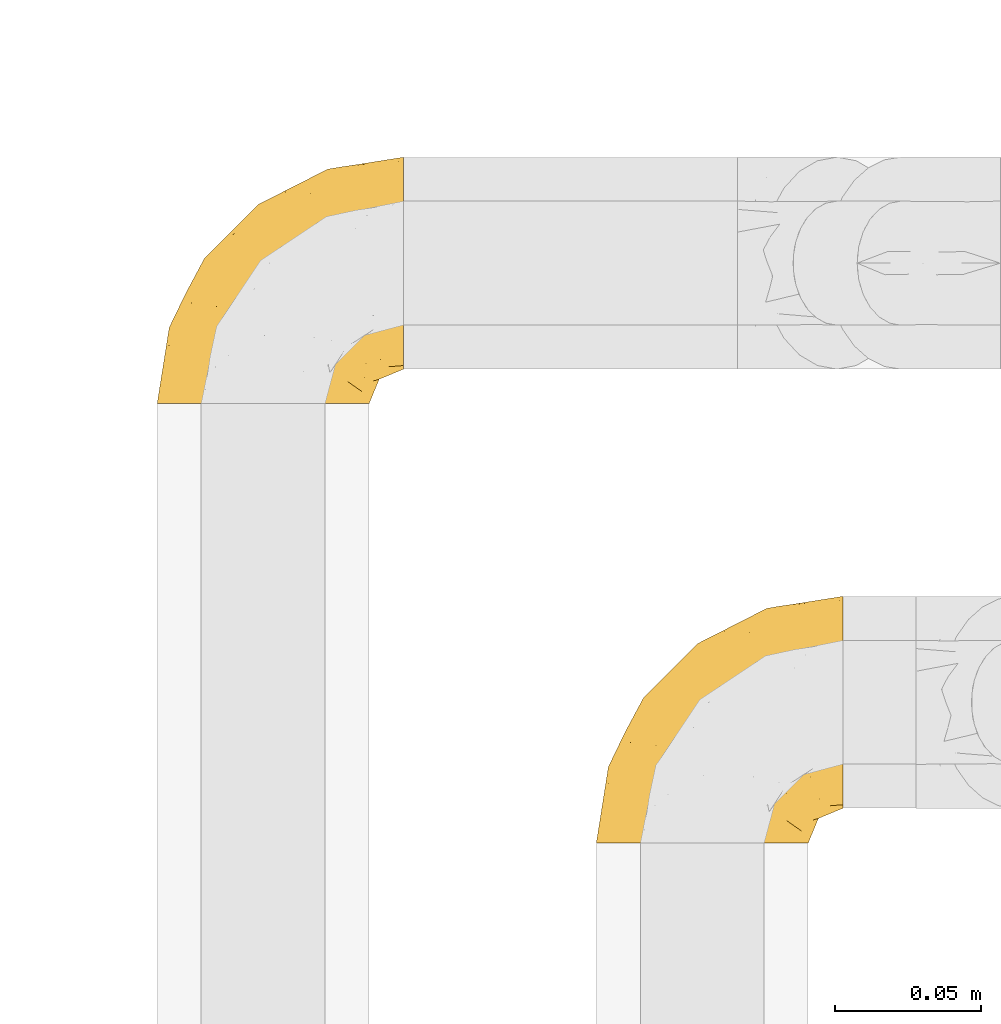
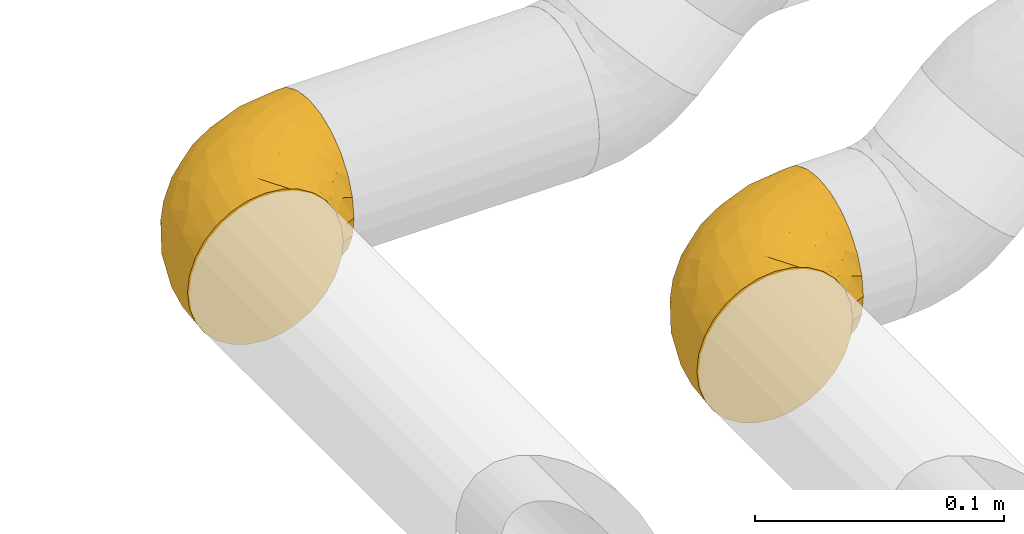
# One storey, part 18 of 39: 2 coverings.
"""IFC2X3 building model written with IfcOpenShell, lengths in millimetres."""

from ifc_helpers import new_model, entity, si_unit, converted_unit, derived_unit, direction, frame, origin, place, context, subcontext, project, spatial, faceted_brep, element, save


model = new_model("IFC2X3")

# Units and contexts
model_context = context("Model", 3, precision=0.01, world=origin(), true_north=direction((6.12303176911189e-17, 1.0)))
body_context = subcontext(model_context, "Body", "Model", "MODEL_VIEW")
ifc_project = project(units=[si_unit("LENGTHUNIT", "METRE", prefix="MILLI"), si_unit("AREAUNIT", "SQUARE_METRE"), si_unit("VOLUMEUNIT", "CUBIC_METRE"), converted_unit("PLANEANGLEUNIT", "DEGREE", entity("IfcRatioMeasure", 0.0174532925199433), si_unit("PLANEANGLEUNIT", "RADIAN"), dimensions=[0, 0, 0, 0, 0, 0, 0]), si_unit("MASSUNIT", "GRAM", prefix="KILO"), derived_unit("MASSDENSITYUNIT", [(si_unit("MASSUNIT", "GRAM", prefix="KILO"), 1), (si_unit("LENGTHUNIT", "METRE"), -3)]), derived_unit("MOMENTOFINERTIAUNIT", [(si_unit("LENGTHUNIT", "METRE"), 4)]), si_unit("TIMEUNIT", "SECOND"), si_unit("FREQUENCYUNIT", "HERTZ"), si_unit("THERMODYNAMICTEMPERATUREUNIT", "DEGREE_CELSIUS"), derived_unit("THERMALTRANSMITTANCEUNIT", [(si_unit("MASSUNIT", "GRAM", prefix="KILO"), 1), (si_unit("THERMODYNAMICTEMPERATUREUNIT", "KELVIN"), -1), (si_unit("TIMEUNIT", "SECOND"), -3)]), derived_unit("VOLUMETRICFLOWRATEUNIT", [(si_unit("LENGTHUNIT", "METRE"), 3), (si_unit("TIMEUNIT", "SECOND"), -1)]), derived_unit("MASSFLOWRATEUNIT", [(si_unit("MASSUNIT", "GRAM", prefix="KILO"), 1), (si_unit("TIMEUNIT", "SECOND"), -1)]), derived_unit("ROTATIONALFREQUENCYUNIT", [(si_unit("TIMEUNIT", "SECOND"), -1)]), si_unit("ELECTRICCURRENTUNIT", "AMPERE"), si_unit("ELECTRICVOLTAGEUNIT", "VOLT"), si_unit("POWERUNIT", "WATT"), si_unit("FORCEUNIT", "NEWTON", prefix="KILO"), si_unit("ILLUMINANCEUNIT", "LUX"), si_unit("LUMINOUSFLUXUNIT", "LUMEN"), si_unit("LUMINOUSINTENSITYUNIT", "CANDELA"), derived_unit("USERDEFINED", [(si_unit("MASSUNIT", "GRAM", prefix="KILO"), -1), (si_unit("LENGTHUNIT", "METRE"), -2), (si_unit("TIMEUNIT", "SECOND"), 3), (si_unit("LUMINOUSFLUXUNIT", "LUMEN"), 1)]), derived_unit("LINEARVELOCITYUNIT", [(si_unit("LENGTHUNIT", "METRE"), 1), (si_unit("TIMEUNIT", "SECOND"), -1)]), si_unit("PRESSUREUNIT", "PASCAL"), derived_unit("USERDEFINED", [(si_unit("LENGTHUNIT", "METRE"), -2), (si_unit("MASSUNIT", "GRAM", prefix="KILO"), 1), (si_unit("TIMEUNIT", "SECOND"), -2)]), derived_unit("LINEARFORCEUNIT", [(si_unit("MASSUNIT", "GRAM", prefix="KILO"), 1), (si_unit("LENGTHUNIT", "METRE"), 1), (si_unit("TIMEUNIT", "SECOND"), -2), (si_unit("LENGTHUNIT", "METRE"), -1)]), derived_unit("PLANARFORCEUNIT", [(si_unit("MASSUNIT", "GRAM", prefix="KILO"), 1), (si_unit("LENGTHUNIT", "METRE"), 1), (si_unit("TIMEUNIT", "SECOND"), -2), (si_unit("LENGTHUNIT", "METRE"), -2)])], contexts=[model_context])

# Site, building, storey
site_placement = place(None, origin())
site = spatial("IfcSite", under=ifc_project, at=site_placement, CompositionType="ELEMENT")
building_placement = place(site_placement, origin())
building = spatial("IfcBuilding", under=site, at=building_placement, CompositionType="ELEMENT")
storey_placement = place(building_placement, frame((0.0, 0.0, 24000.0)))
storey = spatial("IfcBuildingStorey", under=building, at=storey_placement, Name="07", CompositionType="ELEMENT", Elevation=24000.0)

# Coverings
covering_1_placement = place(storey_placement, frame((68632.28, 2675.76, 2992.16)))
element("IfcCovering", 1, at=covering_1_placement, inside=storey, Name=":ADSK_", ObjectType=":ADSK_", PredefinedType="INSULATION", context=body_context, shape_type="Brep", body=[
    faceted_brep([(37.79, 1.6, 74.0), (29.74, 1.6, 73.09), (22.08, 1.6, 70.41), (15.22, 1.6, 66.09), (9.49, 1.6, 60.36), (5.18, 1.6, 53.5), (2.5, 1.6, 45.85), (1.6, 1.6, 37.79), (2.5, 1.6, 29.74), (5.18, 1.6, 22.08), (9.5, 1.6, 15.22), (15.23, 1.6, 9.49), (22.09, 1.6, 5.18), (29.75, 1.6, 2.5), (37.8, 1.6, 1.6), (43.06, 1.6, 2.19), (45.86, 1.6, 2.5), (49.68, 1.6, 3.84), (53.51, 1.6, 5.18), (60.37, 1.6, 9.5), (66.1, 1.6, 15.23), (70.41, 1.6, 22.09), (73.09, 1.6, 29.75), (74.0, 1.6, 37.8), (73.09, 1.6, 45.86), (70.41, 1.6, 53.51), (66.09, 1.6, 60.37), (60.36, 1.6, 66.1), (53.5, 1.6, 70.41), (49.67, 1.6, 71.75), (45.85, 1.6, 73.09), (43.06, 1.6, 73.4), (85.8, 14.63, 28.43), (85.8, 18.25, 19.7), (85.8, 24.0, 12.2), (85.8, 27.75, 9.32), (85.8, 31.5, 6.45), (85.8, 35.86, 4.64), (85.8, 40.23, 2.83), (85.8, 44.31, 2.29), (85.8, 46.95, 1.94), (85.8, 49.6, 1.6), (85.8, 58.96, 2.83), (85.8, 67.7, 6.45), (85.8, 75.19, 12.2), (85.8, 80.95, 19.7), (85.8, 84.56, 28.43), (85.8, 85.8, 37.8), (85.8, 84.56, 47.17), (85.79, 80.95, 55.9), (85.79, 75.19, 63.39), (85.79, 67.7, 69.15), (85.79, 58.96, 72.76), (85.79, 49.6, 74.0), (85.79, 44.31, 73.3), (85.79, 40.23, 72.76), (85.79, 35.86, 70.95), (85.79, 31.5, 69.15), (85.79, 27.75, 66.27), (85.79, 24.0, 63.39), (85.79, 18.25, 55.9), (85.8, 14.63, 47.17), (85.8, 13.4, 37.8), (27.78, 59.61, 50.11), (26.99, 60.4, 37.8), (19.14, 51.32, 46.44), (59.78, 81.67, 37.8), (64.45, 82.49, 44.03), (67.99, 82.98, 37.8), (45.3, 73.87, 47.59), (53.86, 73.39, 57.17), (66.01, 81.11, 50.38), (70.92, 77.75, 58.65), (33.16, 16.46, 73.37), (49.16, 51.34, 71.27), (68.28, 63.37, 70.16), (50.64, 61.46, 66.97), (70.36, 54.83, 73.22), (67.43, 45.94, 74.0), (74.88, 47.42, 74.0), (77.61, 47.97, 74.0), (80.34, 48.51, 74.0), (65.68, 70.77, 64.86), (24.84, 15.75, 70.93), (11.5, 39.56, 45.19), (5.67, 21.48, 48.57), (13.35, 36.01, 54.32), (39.73, 34.58, 72.94), (41.45, 19.96, 74.0), (44.05, 23.86, 74.0), (46.65, 27.75, 74.0), (49.25, 31.64, 74.0), (51.85, 35.54, 74.0), (35.98, 46.13, 68.72), (57.18, 48.41, 73.34), (18.48, 16.74, 67.28), (13.36, 21.75, 61.7), (7.85, 16.31, 55.93), (4.42, 19.4, 37.79), (20.15, 48.77, 53.02), (31.91, 58.66, 57.31), (38.88, 7.05, 74.0), (39.97, 12.51, 74.0), (21.9, 34.87, 64.86), (22.4, 45.71, 59.15), (28.44, 30.95, 70.05), (41.69, 67.5, 55.98), (48.04, 75.69, 37.8), (33.67, 53.35, 63.54), (44.49, 64.73, 61.4), (5.72, 27.61, 37.79), (17.68, 51.09, 37.79), (11.7, 39.35, 37.79), (55.75, 38.14, 74.0), (59.64, 40.74, 74.0), (63.53, 43.34, 74.0), (36.3, 69.71, 37.8), (69.92, 30.92, 70.9), (69.03, 26.47, 69.2), (74.68, 24.1, 65.83), (79.55, 42.08, 73.31), (79.54, 27.56, 67.07), (81.25, 22.68, 62.53), (76.19, 12.9, 52.3), (72.4, 10.56, 54.94), (75.54, 9.38, 46.54), (63.7, 30.49, 72.08), (66.91, 37.21, 73.17), (72.9, 15.4, 59.32), (77.88, 16.56, 56.36), (80.8, 14.21, 48.99), (80.78, 19.1, 58.36), (60.93, 6.65, 66.05), (66.56, 9.22, 61.56), (58.7, 13.56, 68.98), (46.01, 10.43, 73.26), (80.23, 32.68, 70.06), (70.42, 40.02, 73.39), (74.75, 33.01, 70.87), (68.99, 13.09, 61.17), (51.42, 11.85, 71.9), (71.01, 20.93, 65.19), (76.08, 6.64, 37.8), (73.71, 5.68, 46.04), (71.61, 5.7, 52.15), (63.33, 14.76, 66.57), (77.45, 9.94, 37.8), (52.09, 25.2, 73.34), (50.98, 19.66, 72.91), (80.75, 11.31, 37.8), (76.87, 39.13, 72.75), (57.73, 30.86, 73.22), (63.89, 24.56, 70.14), (57.77, 25.09, 72.14), (66.53, 18.54, 66.28), (80.78, 19.1, 17.24), (80.8, 14.22, 26.6), (81.26, 22.68, 13.06), (38.88, 7.05, 1.6), (39.97, 12.51, 1.6), (73.72, 5.68, 29.56), (72.41, 10.57, 20.66), (71.61, 5.7, 23.45), (66.57, 9.22, 14.05), (74.88, 47.42, 1.6), (80.34, 48.51, 1.6), (83.07, 49.05, 1.6), (77.88, 16.56, 19.23), (76.2, 12.9, 23.3), (72.91, 15.39, 16.29), (77.21, 27.52, 8.09), (74.75, 33.0, 4.72), (80.23, 32.67, 5.54), (51.43, 11.86, 3.69), (76.87, 39.13, 2.84), (66.92, 37.21, 2.42), (69.93, 30.92, 4.69), (63.71, 30.49, 3.52), (70.42, 40.02, 2.21), (75.54, 9.38, 29.05), (79.55, 42.08, 2.29), (60.94, 6.65, 9.55), (69.0, 13.09, 14.43), (46.02, 10.43, 2.33), (66.54, 18.54, 9.32), (57.77, 25.08, 3.45), (63.89, 24.56, 5.45), (71.03, 20.93, 10.41), (51.53, 19.57, 2.81), (58.72, 13.56, 6.62), (41.45, 19.96, 1.6), (74.69, 24.1, 9.76), (63.35, 14.76, 9.03), (57.73, 30.85, 2.37), (49.25, 31.64, 1.6), (56.44, 20.0, 4.15), (51.59, 25.27, 2.17), (44.05, 23.86, 1.6), (59.64, 40.74, 1.6), (55.75, 38.14, 1.6), (67.43, 45.94, 1.6), (63.53, 43.34, 1.6), (69.03, 26.46, 6.39), (46.65, 27.75, 1.6), (51.85, 35.54, 1.6), (49.16, 51.33, 4.32), (70.36, 54.83, 2.37), (57.19, 48.41, 2.25), (22.41, 45.7, 16.43), (31.92, 58.67, 18.27), (33.68, 53.34, 12.04), (50.63, 61.46, 8.62), (35.99, 46.13, 6.87), (21.91, 34.86, 10.72), (39.73, 34.58, 2.64), (27.78, 59.61, 25.48), (41.7, 67.49, 19.59), (68.28, 63.37, 5.43), (64.45, 82.49, 31.57), (66.0, 81.11, 25.21), (28.45, 30.94, 5.53), (70.92, 77.75, 16.94), (65.68, 70.77, 10.73), (53.85, 73.39, 18.42), (13.35, 36.01, 21.26), (5.67, 21.48, 27.01), (11.5, 39.57, 30.39), (33.16, 16.45, 2.22), (13.37, 21.75, 13.88), (18.49, 16.74, 8.3), (45.3, 73.87, 28.0), (19.15, 51.31, 29.14), (20.15, 48.77, 22.56), (7.85, 16.32, 19.64), (44.48, 64.71, 14.18), (24.85, 15.75, 4.66)], [[[0, 1, 2, 3, 4, 5, 6, 7, 8, 9, 10, 11, 12, 13, 14, 15, 16, 17, 18, 19, 20, 21, 22, 23, 24, 25, 26, 27, 28, 29, 30, 31]], [[32, 33, 34, 35, 36, 37, 38, 39, 40, 41, 42, 43, 44, 45, 46, 47, 48, 49, 50, 51, 52, 53, 54, 55, 56, 57, 58, 59, 60, 61, 62]], [[63, 64, 65]], [[66, 67, 68]], [[69, 70, 71]], [[71, 70, 72]], [[73, 1, 0]], [[74, 75, 76]], [[49, 48, 71]], [[77, 78, 79, 80, 81, 53]], [[50, 82, 51]], [[72, 50, 49]], [[2, 1, 83]], [[84, 85, 86]], [[87, 88, 89, 90, 91, 92]], [[53, 52, 77]], [[93, 74, 76]], [[5, 85, 6]], [[94, 78, 77]], [[95, 3, 2]], [[95, 96, 3]], [[75, 51, 82]], [[85, 5, 97]], [[50, 72, 82]], [[97, 5, 4]], [[85, 98, 6]], [[94, 87, 92]], [[74, 77, 75]], [[99, 100, 63]], [[96, 4, 3]], [[73, 0, 101, 102, 88]], [[96, 103, 104]], [[48, 68, 67]], [[84, 99, 65]], [[105, 83, 73]], [[105, 95, 83]], [[100, 106, 63]], [[86, 96, 104]], [[97, 86, 85]], [[67, 107, 69]], [[100, 108, 109]], [[84, 110, 85]], [[93, 87, 74]], [[96, 95, 103]], [[69, 71, 67]], [[70, 69, 106]], [[4, 96, 97]], [[86, 97, 96]], [[83, 95, 2]], [[103, 95, 105]], [[93, 103, 105]], [[103, 108, 104]], [[75, 77, 52]], [[94, 77, 74]], [[51, 75, 52]], [[75, 82, 76]], [[109, 82, 70]], [[93, 76, 108]], [[88, 87, 73]], [[105, 73, 87]], [[84, 86, 99]], [[84, 111, 112, 110]], [[98, 85, 110]], [[98, 7, 6]], [[73, 83, 1]], [[71, 72, 49]], [[82, 72, 70]], [[87, 94, 74]], [[94, 92, 113, 114, 115, 78]], [[48, 47, 68]], [[48, 67, 71]], [[100, 104, 108]], [[99, 86, 104]], [[109, 108, 76]], [[100, 109, 106]], [[82, 109, 76]], [[106, 109, 70]], [[100, 99, 104]], [[99, 63, 65]], [[69, 116, 63]], [[111, 84, 65]], [[64, 63, 116]], [[64, 111, 65]], [[63, 106, 69]], [[103, 93, 108]], [[87, 93, 105]], [[107, 67, 66]], [[107, 116, 69]], [[117, 118, 119]], [[80, 120, 55]], [[121, 119, 122]], [[120, 56, 55]], [[123, 124, 125]], [[114, 126, 127]], [[101, 0, 31, 30, 102]], [[123, 128, 124]], [[129, 123, 130]], [[60, 122, 131]], [[132, 133, 134]], [[29, 28, 135]], [[131, 61, 60]], [[122, 60, 59]], [[136, 137, 138]], [[124, 128, 139]], [[132, 27, 26]], [[131, 130, 61]], [[140, 135, 28]], [[102, 29, 135]], [[119, 118, 141]], [[58, 136, 121]], [[140, 28, 27]], [[54, 53, 81, 80, 55]], [[23, 142, 143]], [[24, 144, 25]], [[25, 144, 133]], [[26, 25, 133]], [[134, 133, 145]], [[125, 142, 146]], [[124, 143, 125]], [[147, 90, 148]], [[124, 144, 143]], [[149, 125, 146]], [[150, 57, 56]], [[137, 78, 115]], [[130, 62, 61]], [[132, 140, 27]], [[151, 152, 126]], [[140, 134, 148]], [[148, 89, 140]], [[120, 78, 150]], [[115, 127, 137]], [[137, 136, 150]], [[78, 120, 80, 79]], [[150, 56, 120]], [[91, 151, 92]], [[127, 117, 138]], [[144, 24, 143]], [[133, 144, 124]], [[153, 91, 147]], [[145, 153, 134]], [[23, 143, 24]], [[142, 125, 143]], [[130, 125, 149]], [[128, 123, 129]], [[141, 129, 119]], [[124, 139, 133]], [[125, 130, 123]], [[62, 130, 149]], [[128, 154, 139]], [[145, 139, 154]], [[92, 151, 113]], [[127, 115, 114]], [[117, 127, 126]], [[118, 117, 126]], [[121, 117, 119]], [[138, 137, 127]], [[78, 137, 150]], [[152, 118, 126]], [[118, 152, 141]], [[154, 128, 141]], [[129, 141, 128]], [[102, 30, 29]], [[140, 88, 135]], [[88, 102, 135]], [[133, 132, 26]], [[140, 132, 134]], [[121, 122, 59]], [[131, 119, 129]], [[121, 59, 58]], [[121, 138, 117]], [[136, 58, 57]], [[150, 136, 57]], [[121, 136, 138]], [[119, 131, 122]], [[131, 129, 130]], [[139, 145, 133]], [[153, 145, 154]], [[89, 148, 90]], [[89, 88, 140]], [[147, 134, 153]], [[134, 147, 148]], [[126, 114, 113]], [[153, 151, 91]], [[91, 90, 147]], [[153, 154, 152]], [[152, 154, 141]], [[152, 151, 153]], [[113, 151, 126]], [[155, 32, 156]], [[33, 157, 34]], [[62, 149, 156]], [[15, 14, 158, 159, 16]], [[160, 23, 22]], [[161, 162, 163]], [[40, 39, 38, 164, 165, 166, 41]], [[167, 168, 169]], [[157, 170, 34]], [[171, 172, 170]], [[18, 173, 19]], [[174, 37, 36]], [[175, 176, 177]], [[178, 171, 175]], [[146, 179, 149]], [[168, 179, 161]], [[161, 160, 162]], [[162, 160, 22]], [[38, 37, 180]], [[20, 19, 181]], [[21, 20, 163]], [[161, 182, 169]], [[18, 183, 173]], [[184, 185, 186]], [[169, 187, 167]], [[188, 189, 173]], [[159, 190, 183]], [[17, 159, 183]], [[156, 179, 168]], [[191, 157, 155]], [[192, 163, 189]], [[21, 162, 22]], [[146, 142, 179]], [[181, 163, 20]], [[193, 185, 194]], [[178, 172, 171]], [[167, 156, 168]], [[185, 195, 196]], [[181, 173, 189]], [[173, 197, 188]], [[198, 177, 199]], [[200, 164, 180]], [[180, 164, 38]], [[201, 178, 175]], [[37, 174, 180]], [[200, 180, 174]], [[175, 198, 201]], [[177, 176, 202]], [[163, 162, 21]], [[160, 161, 179]], [[192, 185, 184]], [[195, 189, 188]], [[179, 142, 160]], [[23, 160, 142]], [[169, 168, 161]], [[155, 156, 167]], [[182, 161, 163]], [[184, 186, 187]], [[62, 156, 32]], [[179, 156, 149]], [[192, 182, 163]], [[184, 169, 182]], [[176, 175, 171]], [[174, 178, 200]], [[198, 175, 177]], [[170, 176, 171]], [[202, 176, 191]], [[200, 178, 201]], [[178, 174, 172]], [[187, 202, 191]], [[202, 187, 186]], [[167, 187, 191]], [[169, 184, 187]], [[173, 183, 190]], [[17, 16, 159]], [[173, 181, 19]], [[163, 181, 189]], [[155, 157, 33]], [[170, 157, 191]], [[176, 170, 191]], [[35, 170, 172]], [[35, 172, 36]], [[34, 170, 35]], [[174, 36, 172]], [[32, 155, 33]], [[191, 155, 167]], [[192, 189, 195]], [[182, 192, 184]], [[193, 199, 177]], [[183, 18, 17]], [[197, 173, 190]], [[197, 203, 188]], [[193, 186, 185]], [[202, 186, 177]], [[188, 196, 195]], [[204, 193, 194]], [[188, 203, 196]], [[192, 195, 185]], [[203, 194, 196]], [[185, 196, 194]], [[199, 193, 204]], [[186, 193, 177]], [[205, 206, 207]], [[208, 209, 210]], [[210, 211, 212]], [[210, 213, 208]], [[214, 204, 194, 203, 197, 190]], [[206, 41, 166, 165, 164, 200]], [[215, 216, 209]], [[206, 217, 42]], [[218, 46, 219]], [[207, 214, 205]], [[212, 214, 220]], [[221, 219, 45]], [[45, 219, 46]], [[221, 222, 223]], [[224, 225, 226]], [[222, 44, 43]], [[222, 217, 211]], [[220, 214, 227]], [[227, 190, 159, 158, 14]], [[217, 43, 42]], [[14, 13, 227]], [[225, 9, 8]], [[10, 228, 11]], [[11, 229, 12]], [[208, 213, 228]], [[228, 229, 11]], [[230, 219, 223]], [[231, 232, 226]], [[231, 64, 215]], [[225, 233, 9]], [[229, 213, 220]], [[233, 10, 9]], [[110, 225, 98]], [[41, 206, 42]], [[222, 211, 234]], [[224, 228, 233]], [[225, 8, 98]], [[221, 45, 44]], [[226, 110, 112, 111]], [[12, 229, 235]], [[46, 218, 68]], [[230, 107, 218]], [[223, 234, 216]], [[107, 66, 218]], [[224, 233, 225]], [[228, 10, 233]], [[213, 229, 228]], [[235, 229, 220]], [[208, 228, 224]], [[212, 213, 210]], [[207, 206, 200]], [[205, 211, 217]], [[205, 217, 206]], [[43, 217, 222]], [[212, 211, 205]], [[210, 209, 234]], [[227, 13, 235]], [[214, 190, 227]], [[110, 226, 225]], [[232, 231, 215]], [[8, 7, 98]], [[227, 235, 220]], [[13, 12, 235]], [[222, 221, 44]], [[219, 221, 223]], [[207, 200, 201, 198, 199, 204]], [[214, 207, 204]], [[68, 218, 66]], [[68, 47, 46]], [[230, 218, 219]], [[224, 232, 208]], [[208, 232, 209]], [[216, 215, 230]], [[210, 234, 211]], [[216, 234, 209]], [[222, 234, 223]], [[226, 232, 224]], [[209, 232, 215]], [[226, 111, 231]], [[64, 116, 215]], [[231, 111, 64]], [[116, 230, 215]], [[230, 223, 216]], [[214, 212, 205]], [[213, 212, 220]], [[230, 116, 107]]]),
])
covering_2_placement = place(storey_placement, frame((68482.28, 2825.76, 2992.19)))
element("IfcCovering", 2, at=covering_2_placement, inside=storey, Name=":ADSK_", ObjectType=":ADSK_", PredefinedType="INSULATION", context=body_context, shape_type="Brep", body=[
    faceted_brep([(15.23, 1.6, 66.11), (9.49, 1.6, 60.37), (5.18, 1.6, 53.51), (2.5, 1.6, 45.86), (1.6, 1.6, 37.81), (2.5, 1.6, 29.75), (5.18, 1.6, 22.1), (9.49, 1.6, 15.23), (15.22, 1.6, 9.5), (22.09, 1.6, 5.19), (29.74, 1.6, 2.51), (37.79, 1.6, 1.6), (43.05, 1.6, 2.19), (45.85, 1.6, 2.51), (49.67, 1.6, 3.85), (53.5, 1.6, 5.19), (60.36, 1.6, 9.5), (66.1, 1.6, 15.23), (70.41, 1.6, 22.09), (73.09, 1.6, 29.74), (74.0, 1.6, 37.79), (73.09, 1.6, 45.85), (70.41, 1.6, 53.51), (66.1, 1.6, 60.37), (60.37, 1.6, 66.1), (53.5, 1.6, 70.42), (49.68, 1.6, 71.76), (45.85, 1.6, 73.09), (43.06, 1.6, 73.41), (37.8, 1.6, 74.0), (29.74, 1.6, 73.1), (22.09, 1.6, 70.42), (85.79, 14.63, 28.42), (85.79, 18.25, 19.69), (85.79, 24.0, 12.2), (85.79, 27.75, 9.32), (85.79, 31.5, 6.44), (85.79, 35.87, 4.64), (85.79, 40.23, 2.83), (85.79, 44.32, 2.29), (85.79, 46.96, 1.94), (85.79, 49.6, 1.6), (85.79, 58.97, 2.83), (85.79, 67.7, 6.45), (85.79, 75.2, 12.2), (85.79, 80.95, 19.7), (85.79, 84.57, 28.43), (85.8, 85.8, 37.8), (85.8, 84.56, 47.17), (85.8, 80.95, 55.9), (85.8, 75.19, 63.39), (85.8, 67.7, 69.15), (85.8, 58.96, 72.76), (85.8, 49.6, 74.0), (85.8, 44.31, 73.3), (85.8, 40.23, 72.76), (85.8, 35.86, 70.95), (85.8, 31.5, 69.14), (85.8, 27.75, 66.27), (85.8, 24.0, 63.39), (85.8, 18.25, 55.89), (85.8, 14.63, 47.16), (85.8, 13.4, 37.79), (27.79, 59.61, 50.13), (26.99, 60.4, 37.81), (19.15, 51.32, 46.45), (59.78, 81.68, 37.8), (64.45, 82.49, 44.03), (67.99, 82.98, 37.8), (45.31, 73.88, 47.6), (53.87, 73.4, 57.18), (66.01, 81.12, 50.38), (70.93, 77.75, 58.65), (33.17, 16.46, 73.38), (49.17, 51.34, 71.28), (68.29, 63.37, 70.17), (50.64, 61.46, 66.98), (70.37, 54.83, 73.23), (67.44, 45.94, 74.0), (74.89, 47.42, 74.0), (77.62, 47.97, 74.0), (80.35, 48.51, 74.0), (65.69, 70.77, 64.87), (24.84, 15.75, 70.94), (11.5, 39.56, 45.21), (5.67, 21.48, 48.58), (13.35, 36.02, 54.33), (39.74, 34.58, 72.95), (41.46, 19.96, 74.0), (44.06, 23.86, 74.0), (46.66, 27.75, 74.0), (49.26, 31.64, 74.0), (51.86, 35.54, 74.0), (35.99, 46.13, 68.73), (57.19, 48.41, 73.34), (18.48, 16.74, 67.29), (13.37, 21.75, 61.71), (7.85, 16.32, 55.95), (4.42, 19.4, 37.81), (20.15, 48.78, 53.04), (31.91, 58.66, 57.32), (38.89, 7.05, 74.0), (39.97, 12.51, 74.0), (21.91, 34.87, 64.88), (22.41, 45.71, 59.17), (28.45, 30.95, 70.06), (41.69, 67.5, 55.99), (48.04, 75.7, 37.81), (33.68, 53.35, 63.55), (44.5, 64.73, 61.41), (5.72, 27.62, 37.81), (17.68, 51.09, 37.81), (11.7, 39.35, 37.81), (55.76, 38.14, 74.0), (59.65, 40.74, 74.0), (63.54, 43.34, 74.0), (36.3, 69.72, 37.81), (69.93, 30.92, 70.9), (69.03, 26.47, 69.2), (74.68, 24.1, 65.83), (79.55, 42.08, 73.31), (79.55, 27.56, 67.07), (81.26, 22.68, 62.53), (76.19, 12.9, 52.3), (72.41, 10.57, 54.94), (75.55, 9.38, 46.54), (63.71, 30.49, 72.08), (66.92, 37.21, 73.17), (72.9, 15.4, 59.32), (77.89, 16.56, 56.36), (80.8, 14.22, 48.98), (80.79, 19.1, 58.35), (60.94, 6.65, 66.05), (66.57, 9.22, 61.56), (58.71, 13.56, 68.98), (46.02, 10.43, 73.27), (80.24, 32.68, 70.05), (70.43, 40.02, 73.39), (74.76, 33.01, 70.88), (68.99, 13.09, 61.17), (51.43, 11.85, 71.91), (71.02, 20.93, 65.19), (76.08, 6.64, 37.79), (73.72, 5.68, 46.04), (71.61, 5.7, 52.15), (63.34, 14.76, 66.57), (77.45, 9.94, 37.79), (52.1, 25.2, 73.35), (50.99, 19.66, 72.92), (80.75, 11.31, 37.79), (76.88, 39.14, 72.75), (63.9, 24.56, 70.14), (57.78, 25.09, 72.15), (66.53, 18.54, 66.28), (57.74, 30.86, 73.22), (80.78, 19.1, 17.23), (80.8, 14.22, 26.6), (81.25, 22.68, 13.06), (38.87, 7.06, 1.6), (39.96, 12.52, 1.6), (73.72, 5.68, 29.56), (72.4, 10.57, 20.66), (71.61, 5.71, 23.45), (66.57, 9.22, 14.05), (74.87, 47.43, 1.6), (80.33, 48.52, 1.6), (83.06, 49.06, 1.6), (77.88, 16.56, 19.23), (76.19, 12.9, 23.3), (72.91, 15.4, 16.29), (77.2, 27.53, 8.09), (74.75, 33.01, 4.72), (80.22, 32.68, 5.54), (51.42, 11.87, 3.69), (76.86, 39.14, 2.84), (66.91, 37.22, 2.42), (69.92, 30.93, 4.7), (63.7, 30.49, 3.52), (70.41, 40.02, 2.21), (75.54, 9.38, 29.05), (79.54, 42.09, 2.29), (60.94, 6.66, 9.55), (68.99, 13.09, 14.43), (46.01, 10.43, 2.34), (57.76, 25.08, 3.45), (57.72, 30.86, 2.38), (63.88, 24.57, 5.46), (71.02, 20.93, 10.41), (51.52, 19.57, 2.82), (58.71, 13.56, 6.62), (41.44, 19.97, 1.6), (74.68, 24.1, 9.76), (63.34, 14.76, 9.03), (49.25, 31.65, 1.6), (56.43, 20.01, 4.15), (51.59, 25.28, 2.17), (44.04, 23.86, 1.6), (59.63, 40.74, 1.6), (55.74, 38.14, 1.6), (67.42, 45.95, 1.6), (63.53, 43.35, 1.6), (69.02, 26.47, 6.39), (66.53, 18.54, 9.32), (46.64, 27.76, 1.6), (51.85, 35.54, 1.6), (49.16, 51.34, 4.33), (70.35, 54.84, 2.37), (57.18, 48.42, 2.26), (22.41, 45.71, 16.44), (31.91, 58.67, 18.29), (33.67, 53.35, 12.06), (50.62, 61.46, 8.63), (35.98, 46.13, 6.88), (21.9, 34.87, 10.73), (39.72, 34.58, 2.65), (27.78, 59.61, 25.49), (41.69, 67.49, 19.6), (68.27, 63.37, 5.43), (64.45, 82.49, 31.57), (66.0, 81.12, 25.22), (28.44, 30.95, 5.54), (70.91, 77.75, 16.95), (65.67, 70.77, 10.73), (53.85, 73.4, 18.43), (13.35, 36.02, 21.28), (5.67, 21.48, 27.03), (11.5, 39.57, 30.4), (33.16, 16.46, 2.23), (13.37, 21.76, 13.89), (18.48, 16.75, 8.32), (45.3, 73.88, 28.01), (19.14, 51.31, 29.15), (20.15, 48.78, 22.57), (7.85, 16.32, 19.66), (44.48, 64.72, 14.19), (24.84, 15.76, 4.67)], [[[0, 1, 2, 3, 4, 5, 6, 7, 8, 9, 10, 11, 12, 13, 14, 15, 16, 17, 18, 19, 20, 21, 22, 23, 24, 25, 26, 27, 28, 29, 30, 31]], [[32, 33, 34, 35, 36, 37, 38, 39, 40, 41, 42, 43, 44, 45, 46, 47, 48, 49, 50, 51, 52, 53, 54, 55, 56, 57, 58, 59, 60, 61, 62]], [[63, 64, 65]], [[66, 67, 68]], [[69, 70, 71]], [[71, 70, 72]], [[73, 30, 29]], [[74, 75, 76]], [[49, 48, 71]], [[77, 78, 79, 80, 81, 53]], [[50, 82, 51]], [[72, 50, 49]], [[31, 30, 83]], [[84, 85, 86]], [[87, 88, 89, 90, 91, 92]], [[53, 52, 77]], [[93, 74, 76]], [[2, 85, 3]], [[94, 78, 77]], [[95, 0, 31]], [[95, 96, 0]], [[75, 51, 82]], [[85, 2, 97]], [[50, 72, 82]], [[97, 2, 1]], [[85, 98, 3]], [[94, 87, 92]], [[74, 77, 75]], [[99, 100, 63]], [[96, 1, 0]], [[73, 29, 101, 102, 88]], [[96, 103, 104]], [[48, 68, 67]], [[84, 99, 65]], [[105, 83, 73]], [[105, 95, 83]], [[100, 106, 63]], [[86, 96, 104]], [[97, 86, 85]], [[67, 107, 69]], [[100, 108, 109]], [[84, 110, 85]], [[93, 87, 74]], [[96, 95, 103]], [[69, 71, 67]], [[70, 69, 106]], [[1, 96, 97]], [[86, 97, 96]], [[83, 95, 31]], [[103, 95, 105]], [[93, 103, 105]], [[103, 108, 104]], [[75, 77, 52]], [[94, 77, 74]], [[51, 75, 52]], [[75, 82, 76]], [[109, 82, 70]], [[93, 76, 108]], [[88, 87, 73]], [[105, 73, 87]], [[84, 86, 99]], [[84, 111, 112, 110]], [[98, 85, 110]], [[98, 4, 3]], [[73, 83, 30]], [[71, 72, 49]], [[82, 72, 70]], [[87, 94, 74]], [[94, 92, 113, 114, 115, 78]], [[48, 47, 68]], [[48, 67, 71]], [[100, 104, 108]], [[99, 86, 104]], [[109, 108, 76]], [[100, 109, 106]], [[82, 109, 76]], [[106, 109, 70]], [[100, 99, 104]], [[99, 63, 65]], [[69, 116, 63]], [[111, 84, 65]], [[64, 63, 116]], [[64, 111, 65]], [[63, 106, 69]], [[103, 93, 108]], [[87, 93, 105]], [[107, 67, 66]], [[107, 116, 69]], [[117, 118, 119]], [[80, 120, 55]], [[121, 119, 122]], [[120, 56, 55]], [[123, 124, 125]], [[114, 126, 127]], [[101, 29, 28, 27, 102]], [[123, 128, 124]], [[129, 123, 130]], [[60, 122, 131]], [[132, 133, 134]], [[26, 25, 135]], [[131, 61, 60]], [[122, 60, 59]], [[136, 137, 138]], [[124, 128, 139]], [[132, 24, 23]], [[131, 130, 61]], [[140, 135, 25]], [[102, 26, 135]], [[119, 118, 141]], [[58, 136, 121]], [[140, 25, 24]], [[54, 53, 81, 80, 55]], [[20, 142, 143]], [[21, 144, 22]], [[22, 144, 133]], [[23, 22, 133]], [[134, 133, 145]], [[125, 142, 146]], [[124, 143, 125]], [[147, 90, 148]], [[124, 144, 143]], [[149, 125, 146]], [[150, 57, 56]], [[137, 78, 115]], [[130, 62, 61]], [[132, 140, 24]], [[151, 152, 153]], [[140, 134, 148]], [[148, 89, 140]], [[120, 78, 150]], [[115, 127, 137]], [[137, 136, 150]], [[78, 120, 80, 79]], [[150, 56, 120]], [[152, 151, 154]], [[127, 117, 138]], [[144, 21, 143]], [[133, 144, 124]], [[152, 91, 147]], [[145, 152, 134]], [[20, 143, 21]], [[142, 125, 143]], [[130, 125, 149]], [[128, 123, 129]], [[141, 129, 119]], [[124, 139, 133]], [[125, 130, 123]], [[62, 130, 149]], [[128, 153, 139]], [[145, 139, 153]], [[92, 154, 113]], [[127, 115, 114]], [[117, 127, 126]], [[118, 117, 126]], [[121, 117, 119]], [[138, 137, 127]], [[78, 137, 150]], [[151, 118, 126]], [[118, 151, 141]], [[153, 128, 141]], [[129, 141, 128]], [[102, 27, 26]], [[140, 88, 135]], [[88, 102, 135]], [[133, 132, 23]], [[140, 132, 134]], [[121, 122, 59]], [[131, 119, 129]], [[121, 59, 58]], [[121, 138, 117]], [[136, 58, 57]], [[150, 136, 57]], [[121, 136, 138]], [[119, 131, 122]], [[131, 129, 130]], [[139, 145, 133]], [[152, 145, 153]], [[89, 148, 90]], [[89, 88, 140]], [[147, 134, 152]], [[134, 147, 148]], [[126, 114, 113]], [[152, 154, 91]], [[91, 90, 147]], [[151, 153, 141]], [[154, 151, 126]], [[113, 154, 126]], [[91, 154, 92]], [[155, 32, 156]], [[33, 157, 34]], [[62, 149, 156]], [[12, 11, 158, 159, 13]], [[160, 20, 19]], [[161, 162, 163]], [[40, 39, 38, 164, 165, 166, 41]], [[167, 168, 169]], [[157, 170, 34]], [[171, 172, 170]], [[15, 173, 16]], [[174, 37, 36]], [[175, 176, 177]], [[178, 171, 175]], [[146, 179, 149]], [[168, 179, 161]], [[161, 160, 162]], [[162, 160, 19]], [[38, 37, 180]], [[17, 16, 181]], [[18, 17, 163]], [[161, 182, 169]], [[15, 183, 173]], [[184, 185, 186]], [[169, 187, 167]], [[188, 189, 173]], [[159, 190, 183]], [[14, 159, 183]], [[156, 179, 168]], [[191, 157, 155]], [[192, 163, 189]], [[18, 162, 19]], [[146, 142, 179]], [[181, 163, 17]], [[185, 184, 193]], [[170, 172, 35]], [[167, 156, 168]], [[184, 194, 195]], [[181, 173, 189]], [[173, 196, 188]], [[197, 177, 198]], [[199, 164, 180]], [[180, 164, 38]], [[200, 178, 175]], [[37, 174, 180]], [[199, 180, 174]], [[175, 197, 200]], [[177, 176, 201]], [[163, 162, 18]], [[160, 161, 179]], [[192, 184, 202]], [[194, 189, 188]], [[179, 142, 160]], [[20, 160, 142]], [[169, 168, 161]], [[155, 156, 167]], [[182, 161, 163]], [[202, 186, 187]], [[62, 156, 32]], [[179, 156, 149]], [[192, 182, 163]], [[202, 169, 182]], [[176, 175, 171]], [[174, 178, 199]], [[197, 175, 177]], [[170, 176, 171]], [[201, 176, 191]], [[199, 178, 200]], [[178, 174, 172]], [[187, 201, 191]], [[201, 187, 186]], [[167, 187, 191]], [[169, 202, 187]], [[173, 183, 190]], [[14, 13, 159]], [[173, 181, 16]], [[163, 181, 189]], [[155, 157, 33]], [[170, 157, 191]], [[176, 170, 191]], [[172, 36, 35]], [[172, 174, 36]], [[34, 170, 35]], [[172, 171, 178]], [[32, 155, 33]], [[191, 155, 167]], [[192, 189, 194]], [[182, 192, 202]], [[185, 198, 177]], [[183, 15, 14]], [[196, 173, 190]], [[196, 203, 188]], [[201, 186, 177]], [[202, 184, 186]], [[188, 195, 194]], [[204, 185, 193]], [[188, 203, 195]], [[192, 194, 184]], [[203, 193, 195]], [[184, 195, 193]], [[198, 185, 204]], [[186, 185, 177]], [[205, 206, 207]], [[208, 209, 210]], [[210, 211, 212]], [[210, 213, 208]], [[214, 204, 193, 203, 196, 190]], [[206, 41, 166, 165, 164, 199]], [[215, 216, 209]], [[206, 217, 42]], [[218, 46, 219]], [[207, 214, 205]], [[212, 214, 220]], [[221, 219, 45]], [[45, 219, 46]], [[221, 222, 223]], [[224, 225, 226]], [[222, 44, 43]], [[222, 217, 211]], [[220, 214, 227]], [[227, 190, 159, 158, 11]], [[217, 43, 42]], [[11, 10, 227]], [[225, 6, 5]], [[7, 228, 8]], [[8, 229, 9]], [[208, 213, 228]], [[228, 229, 8]], [[230, 219, 223]], [[231, 232, 226]], [[231, 64, 215]], [[225, 233, 6]], [[229, 213, 220]], [[233, 7, 6]], [[110, 225, 98]], [[41, 206, 42]], [[222, 211, 234]], [[224, 228, 233]], [[225, 5, 98]], [[221, 45, 44]], [[226, 110, 112, 111]], [[9, 229, 235]], [[46, 218, 68]], [[230, 107, 218]], [[223, 234, 216]], [[107, 66, 218]], [[224, 233, 225]], [[228, 7, 233]], [[213, 229, 228]], [[235, 229, 220]], [[208, 228, 224]], [[212, 213, 210]], [[207, 206, 199]], [[205, 211, 217]], [[205, 217, 206]], [[43, 217, 222]], [[212, 211, 205]], [[210, 209, 234]], [[227, 10, 235]], [[214, 190, 227]], [[110, 226, 225]], [[232, 231, 215]], [[5, 4, 98]], [[227, 235, 220]], [[10, 9, 235]], [[222, 221, 44]], [[219, 221, 223]], [[207, 199, 200, 197, 198, 204]], [[214, 207, 204]], [[68, 218, 66]], [[68, 47, 46]], [[230, 218, 219]], [[224, 232, 208]], [[208, 232, 209]], [[216, 215, 230]], [[210, 234, 211]], [[216, 234, 209]], [[222, 234, 223]], [[226, 232, 224]], [[209, 232, 215]], [[226, 111, 231]], [[64, 116, 215]], [[231, 111, 64]], [[116, 230, 215]], [[230, 223, 216]], [[214, 212, 205]], [[213, 212, 220]], [[230, 116, 107]]]),
])

save(model, "model.ifc")
